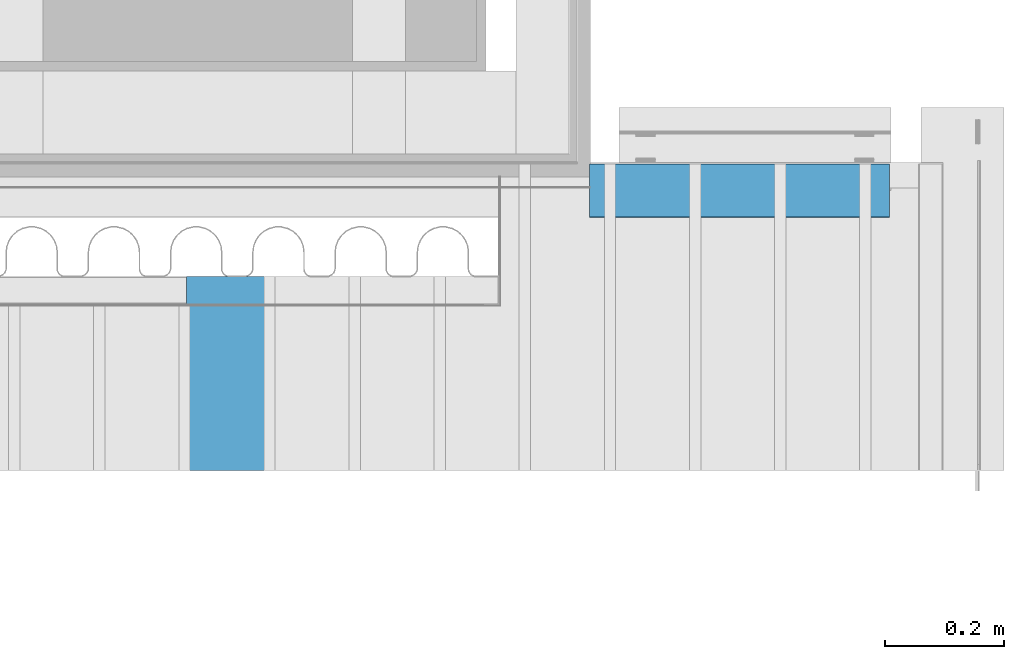
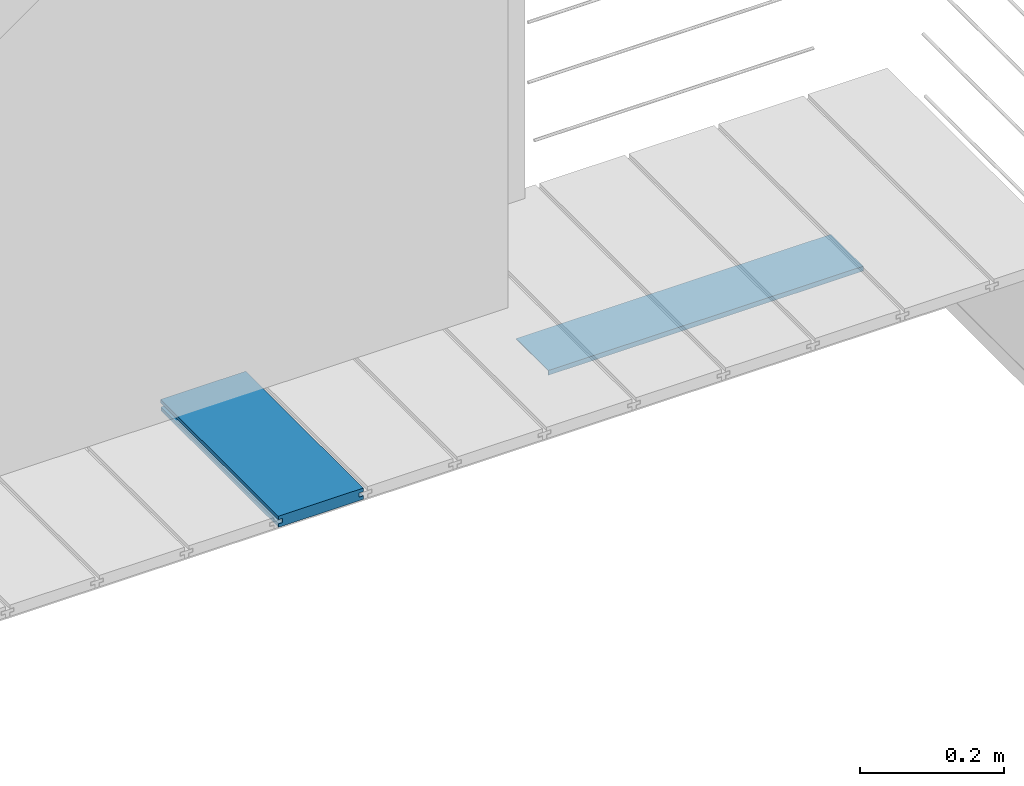
# One storey, part 23 of 33: 2 walls.
"""IFC4 building model written with IfcOpenShell, lengths in feet."""

from ifc_helpers import new_model, entity, si_unit, converted_unit, derived_unit, direction, frame, origin, place, context, subcontext, project, spatial, material, type_object, element, save


model = new_model("IFC4")

# Units and contexts
model_context = context("Model", 3, precision=0.0001, world=origin(), true_north=direction((6.12303176911189e-17, 1.0)))
body_context = subcontext(model_context, "Body", "Model", "MODEL_VIEW")
ifc_project = project(units=[converted_unit("LENGTHUNIT", "FOOT", entity("IfcRatioMeasure", 0.3048), si_unit("LENGTHUNIT", "METRE"), dimensions=[1, 0, 0, 0, 0, 0, 0]), converted_unit("AREAUNIT", "SQUARE FOOT", entity("IfcRatioMeasure", 0.09290304), si_unit("AREAUNIT", "SQUARE_METRE"), dimensions=[2, 0, 0, 0, 0, 0, 0]), converted_unit("VOLUMEUNIT", "CUBIC FOOT", entity("IfcRatioMeasure", 0.028316846592), si_unit("VOLUMEUNIT", "CUBIC_METRE"), dimensions=[3, 0, 0, 0, 0, 0, 0]), converted_unit("PLANEANGLEUNIT", "DEGREE", entity("IfcRatioMeasure", 0.0174532925199433), si_unit("PLANEANGLEUNIT", "RADIAN"), dimensions=[0, 0, 0, 0, 0, 0, 0]), si_unit("MASSUNIT", "GRAM", prefix="KILO"), derived_unit("MASSDENSITYUNIT", [(si_unit("MASSUNIT", "GRAM", prefix="KILO"), 1), (si_unit("LENGTHUNIT", "METRE"), -3)]), derived_unit("MOMENTOFINERTIAUNIT", [(si_unit("LENGTHUNIT", "METRE"), 4)]), si_unit("TIMEUNIT", "SECOND"), si_unit("FREQUENCYUNIT", "HERTZ"), si_unit("THERMODYNAMICTEMPERATUREUNIT", "DEGREE_CELSIUS"), derived_unit("THERMALTRANSMITTANCEUNIT", [(si_unit("MASSUNIT", "GRAM", prefix="KILO"), 1), (si_unit("THERMODYNAMICTEMPERATUREUNIT", "KELVIN"), -1), (si_unit("TIMEUNIT", "SECOND"), -3)]), derived_unit("VOLUMETRICFLOWRATEUNIT", [(si_unit("LENGTHUNIT", "METRE"), 3), (si_unit("TIMEUNIT", "SECOND"), -1)]), si_unit("ELECTRICCURRENTUNIT", "AMPERE"), si_unit("ELECTRICVOLTAGEUNIT", "VOLT"), si_unit("POWERUNIT", "WATT"), si_unit("FORCEUNIT", "NEWTON"), si_unit("ILLUMINANCEUNIT", "LUX"), si_unit("LUMINOUSFLUXUNIT", "LUMEN"), si_unit("LUMINOUSINTENSITYUNIT", "CANDELA"), derived_unit("USERDEFINED", [(si_unit("MASSUNIT", "GRAM", prefix="KILO"), -1), (si_unit("LENGTHUNIT", "METRE"), -2), (si_unit("TIMEUNIT", "SECOND"), 3), (si_unit("LUMINOUSFLUXUNIT", "LUMEN"), 1)]), derived_unit("LINEARVELOCITYUNIT", [(si_unit("LENGTHUNIT", "METRE"), 1), (si_unit("TIMEUNIT", "SECOND"), -1)]), si_unit("PRESSUREUNIT", "PASCAL"), derived_unit("USERDEFINED", [(si_unit("LENGTHUNIT", "METRE"), -2), (si_unit("MASSUNIT", "GRAM", prefix="KILO"), 1), (si_unit("TIMEUNIT", "SECOND"), -2)]), derived_unit("LINEARFORCEUNIT", [(si_unit("MASSUNIT", "GRAM", prefix="KILO"), 1), (si_unit("LENGTHUNIT", "METRE"), 1), (si_unit("TIMEUNIT", "SECOND"), -2), (si_unit("LENGTHUNIT", "METRE"), -1)]), derived_unit("PLANARFORCEUNIT", [(si_unit("MASSUNIT", "GRAM", prefix="KILO"), 1), (si_unit("LENGTHUNIT", "METRE"), 1), (si_unit("TIMEUNIT", "SECOND"), -2), (si_unit("LENGTHUNIT", "METRE"), -2)])], contexts=[model_context])

# Site, building, storey
site_placement = place(None, origin())
site = spatial("IfcSite", under=ifc_project, at=site_placement, CompositionType="ELEMENT")
building_placement = place(site_placement, origin())
building = spatial("IfcBuilding", under=site, at=building_placement, CompositionType="ELEMENT")
storey_placement = place(building_placement, frame((0.0, 0.0, 10.0)))
storey = spatial("IfcBuildingStorey", under=building, at=storey_placement, Name="2ND FLOOR", CompositionType="ELEMENT", Elevation=10.0000000000002)

# Walls
ifc_material_1 = material(Name="COMPOSITE DECKING W/ HIDDEN FASTENERS", Category="Materials")
wall_type_1 = type_object("IfcWallType", Name="Generic Models 716:Generic Models 1", PredefinedType="NOTDEFINED", material=ifc_material_1)
wall_1_placement = place(storey_placement, frame((1490.12212393819, 3.04611392999271, 0.68290215715014), z_axis=(0.0, 0.0, 1.0), x_axis=(0.0, 1.0, 0.0)))
cartesian_point_1 = entity("IfcCartesianPoint", [1.07004500651839, -0.446740923891412, 0.0])
vertex_point_1 = entity("IfcVertexPoint", cartesian_point_1)
cartesian_point_2 = entity("IfcCartesianPoint", [1.07004500651839, -0.00132475379450625, 0.0])
vertex_point_2 = entity("IfcVertexPoint", cartesian_point_2)
ifc_direction_1 = entity("IfcDirection", [0.0, 1.0, 0.0])
edge_curve_1 = entity("IfcEdgeCurve", vertex_point_1, vertex_point_2, entity("IfcTrimmedCurve", entity("IfcLine", cartesian_point_1, entity("IfcVector", ifc_direction_1, 1.0)), [cartesian_point_1], [cartesian_point_2], True, "CARTESIAN"), True)
cartesian_point_3 = entity("IfcCartesianPoint", [1.07004500651839, -0.00132475379450625, 0.0198779960861479])
vertex_point_3 = entity("IfcVertexPoint", cartesian_point_3)
ifc_direction_2 = entity("IfcDirection", [0.0, 0.0, 1.0])
edge_curve_2 = entity("IfcEdgeCurve", vertex_point_2, vertex_point_3, entity("IfcTrimmedCurve", entity("IfcLine", cartesian_point_2, entity("IfcVector", ifc_direction_2, 1.0)), [cartesian_point_2], [cartesian_point_3], True, "CARTESIAN"), True)
cartesian_point_4 = entity("IfcCartesianPoint", [1.07004500651839, -0.0228400010807945, 0.0198779960861479])
vertex_point_4 = entity("IfcVertexPoint", cartesian_point_4)
ifc_direction_3 = entity("IfcDirection", [0.0, -1.0, 0.0])
edge_curve_3 = entity("IfcEdgeCurve", vertex_point_3, vertex_point_4, entity("IfcTrimmedCurve", entity("IfcLine", cartesian_point_3, entity("IfcVector", ifc_direction_3, 1.0)), [cartesian_point_3], [cartesian_point_4], True, "CARTESIAN"), True)
cartesian_point_5 = entity("IfcCartesianPoint", [1.07004500651839, -0.0228400010807945, 0.0422987663426522])
vertex_point_5 = entity("IfcVertexPoint", cartesian_point_5)
edge_curve_4 = entity("IfcEdgeCurve", vertex_point_4, vertex_point_5, entity("IfcTrimmedCurve", entity("IfcLine", cartesian_point_4, entity("IfcVector", ifc_direction_2, 1.0)), [cartesian_point_4], [cartesian_point_5], True, "CARTESIAN"), True)
cartesian_point_6 = entity("IfcCartesianPoint", [1.07004500651839, 0.0, 0.0422987663426522])
vertex_point_6 = entity("IfcVertexPoint", cartesian_point_6)
edge_curve_5 = entity("IfcEdgeCurve", vertex_point_5, vertex_point_6, entity("IfcTrimmedCurve", entity("IfcLine", cartesian_point_5, entity("IfcVector", ifc_direction_1, 1.0)), [cartesian_point_5], [cartesian_point_6], True, "CARTESIAN"), True)
cartesian_point_7 = entity("IfcCartesianPoint", [1.07004500651839, 0.0, 0.0625000000000551])
vertex_point_7 = entity("IfcVertexPoint", cartesian_point_7)
edge_curve_6 = entity("IfcEdgeCurve", vertex_point_6, vertex_point_7, entity("IfcTrimmedCurve", entity("IfcLine", cartesian_point_6, entity("IfcVector", ifc_direction_2, 1.0)), [cartesian_point_6], [cartesian_point_7], True, "CARTESIAN"), True)
cartesian_point_8 = entity("IfcCartesianPoint", [1.07004500651839, -0.446740923891639, 0.0625])
vertex_point_8 = entity("IfcVertexPoint", cartesian_point_8)
edge_curve_7 = entity("IfcEdgeCurve", vertex_point_7, vertex_point_8, entity("IfcTrimmedCurve", entity("IfcLine", cartesian_point_7, entity("IfcVector", ifc_direction_3, 1.0)), [cartesian_point_7], [cartesian_point_8], True, "CARTESIAN"), True)
cartesian_point_9 = entity("IfcCartesianPoint", [1.07004500651839, -0.446740923891639, 0.0422987663426522])
vertex_point_9 = entity("IfcVertexPoint", cartesian_point_9)
ifc_direction_4 = entity("IfcDirection", [0.0, 0.0, -1.0])
edge_curve_8 = entity("IfcEdgeCurve", vertex_point_8, vertex_point_9, entity("IfcTrimmedCurve", entity("IfcLine", cartesian_point_8, entity("IfcVector", ifc_direction_4, 1.0)), [cartesian_point_8], [cartesian_point_9], True, "CARTESIAN"), True)
cartesian_point_10 = entity("IfcCartesianPoint", [1.07004500651839, -0.423900922810617, 0.0422987663426522])
vertex_point_10 = entity("IfcVertexPoint", cartesian_point_10)
edge_curve_9 = entity("IfcEdgeCurve", vertex_point_9, vertex_point_10, entity("IfcTrimmedCurve", entity("IfcLine", cartesian_point_9, entity("IfcVector", ifc_direction_1, 1.0)), [cartesian_point_9], [cartesian_point_10], True, "CARTESIAN"), True)
cartesian_point_11 = entity("IfcCartesianPoint", [1.07004500651839, -0.423900922810617, 0.0198779960861479])
vertex_point_11 = entity("IfcVertexPoint", cartesian_point_11)
edge_curve_10 = entity("IfcEdgeCurve", vertex_point_10, vertex_point_11, entity("IfcTrimmedCurve", entity("IfcLine", cartesian_point_10, entity("IfcVector", ifc_direction_4, 1.0)), [cartesian_point_10], [cartesian_point_11], True, "CARTESIAN"), True)
cartesian_point_12 = entity("IfcCartesianPoint", [1.07004500651839, -0.446740923891412, 0.0198779960861479])
vertex_point_12 = entity("IfcVertexPoint", cartesian_point_12)
edge_curve_11 = entity("IfcEdgeCurve", vertex_point_11, vertex_point_12, entity("IfcTrimmedCurve", entity("IfcLine", cartesian_point_11, entity("IfcVector", ifc_direction_3, 1.0)), [cartesian_point_11], [cartesian_point_12], True, "CARTESIAN"), True)
edge_curve_12 = entity("IfcEdgeCurve", vertex_point_12, vertex_point_1, entity("IfcTrimmedCurve", entity("IfcLine", cartesian_point_12, entity("IfcVector", ifc_direction_4, 1.0)), [cartesian_point_12], [cartesian_point_1], True, "CARTESIAN"), True)
ifc_direction_5 = entity("IfcDirection", [1.0, 0.0, 0.0])
cartesian_point_13 = entity("IfcCartesianPoint", [0.0, -0.446740923891412, 0.0])
vertex_point_13 = entity("IfcVertexPoint", cartesian_point_13)
cartesian_point_14 = entity("IfcCartesianPoint", [0.0, -0.446740923891412, 0.0198779960861479])
vertex_point_14 = entity("IfcVertexPoint", cartesian_point_14)
edge_curve_13 = entity("IfcEdgeCurve", vertex_point_13, vertex_point_14, entity("IfcTrimmedCurve", entity("IfcLine", cartesian_point_13, entity("IfcVector", ifc_direction_2, 1.0)), [cartesian_point_13], [cartesian_point_14], True, "CARTESIAN"), True)
cartesian_point_15 = entity("IfcCartesianPoint", [0.0, -0.423900922810617, 0.0198779960861479])
vertex_point_15 = entity("IfcVertexPoint", cartesian_point_15)
edge_curve_14 = entity("IfcEdgeCurve", vertex_point_14, vertex_point_15, entity("IfcTrimmedCurve", entity("IfcLine", cartesian_point_14, entity("IfcVector", ifc_direction_1, 1.0)), [cartesian_point_14], [cartesian_point_15], True, "CARTESIAN"), True)
cartesian_point_16 = entity("IfcCartesianPoint", [0.0, -0.423900922810617, 0.0422987663426522])
vertex_point_16 = entity("IfcVertexPoint", cartesian_point_16)
edge_curve_15 = entity("IfcEdgeCurve", vertex_point_15, vertex_point_16, entity("IfcTrimmedCurve", entity("IfcLine", cartesian_point_15, entity("IfcVector", ifc_direction_2, 1.0)), [cartesian_point_15], [cartesian_point_16], True, "CARTESIAN"), True)
cartesian_point_17 = entity("IfcCartesianPoint", [0.0, -0.446740923891639, 0.0422987663426522])
vertex_point_17 = entity("IfcVertexPoint", cartesian_point_17)
edge_curve_16 = entity("IfcEdgeCurve", vertex_point_16, vertex_point_17, entity("IfcTrimmedCurve", entity("IfcLine", cartesian_point_16, entity("IfcVector", ifc_direction_3, 1.0)), [cartesian_point_16], [cartesian_point_17], True, "CARTESIAN"), True)
cartesian_point_18 = entity("IfcCartesianPoint", [0.0, -0.446740923891639, 0.0625])
vertex_point_18 = entity("IfcVertexPoint", cartesian_point_18)
edge_curve_17 = entity("IfcEdgeCurve", vertex_point_17, vertex_point_18, entity("IfcTrimmedCurve", entity("IfcLine", cartesian_point_17, entity("IfcVector", ifc_direction_2, 1.0)), [cartesian_point_17], [cartesian_point_18], True, "CARTESIAN"), True)
cartesian_point_19 = entity("IfcCartesianPoint", [0.0, 0.0, 0.0625000000000551])
vertex_point_19 = entity("IfcVertexPoint", cartesian_point_19)
edge_curve_18 = entity("IfcEdgeCurve", vertex_point_18, vertex_point_19, entity("IfcTrimmedCurve", entity("IfcLine", cartesian_point_18, entity("IfcVector", ifc_direction_1, 1.0)), [cartesian_point_18], [cartesian_point_19], True, "CARTESIAN"), True)
cartesian_point_20 = entity("IfcCartesianPoint", [0.0, 0.0, 0.0422987663426522])
vertex_point_20 = entity("IfcVertexPoint", cartesian_point_20)
edge_curve_19 = entity("IfcEdgeCurve", vertex_point_19, vertex_point_20, entity("IfcTrimmedCurve", entity("IfcLine", cartesian_point_19, entity("IfcVector", ifc_direction_4, 1.0)), [cartesian_point_19], [cartesian_point_20], True, "CARTESIAN"), True)
cartesian_point_21 = entity("IfcCartesianPoint", [0.0, -0.0228400010807945, 0.0422987663426522])
vertex_point_21 = entity("IfcVertexPoint", cartesian_point_21)
edge_curve_20 = entity("IfcEdgeCurve", vertex_point_20, vertex_point_21, entity("IfcTrimmedCurve", entity("IfcLine", cartesian_point_20, entity("IfcVector", ifc_direction_3, 1.0)), [cartesian_point_20], [cartesian_point_21], True, "CARTESIAN"), True)
cartesian_point_22 = entity("IfcCartesianPoint", [0.0, -0.0228400010807945, 0.0198779960861479])
vertex_point_22 = entity("IfcVertexPoint", cartesian_point_22)
edge_curve_21 = entity("IfcEdgeCurve", vertex_point_21, vertex_point_22, entity("IfcTrimmedCurve", entity("IfcLine", cartesian_point_21, entity("IfcVector", ifc_direction_4, 1.0)), [cartesian_point_21], [cartesian_point_22], True, "CARTESIAN"), True)
cartesian_point_23 = entity("IfcCartesianPoint", [0.0, -0.00132475379450625, 0.0198779960861479])
vertex_point_23 = entity("IfcVertexPoint", cartesian_point_23)
edge_curve_22 = entity("IfcEdgeCurve", vertex_point_22, vertex_point_23, entity("IfcTrimmedCurve", entity("IfcLine", cartesian_point_22, entity("IfcVector", ifc_direction_1, 1.0)), [cartesian_point_22], [cartesian_point_23], True, "CARTESIAN"), True)
cartesian_point_24 = entity("IfcCartesianPoint", [0.0, -0.00132475379450625, 0.0])
vertex_point_24 = entity("IfcVertexPoint", cartesian_point_24)
edge_curve_23 = entity("IfcEdgeCurve", vertex_point_23, vertex_point_24, entity("IfcTrimmedCurve", entity("IfcLine", cartesian_point_23, entity("IfcVector", ifc_direction_4, 1.0)), [cartesian_point_23], [cartesian_point_24], True, "CARTESIAN"), True)
edge_curve_24 = entity("IfcEdgeCurve", vertex_point_24, vertex_point_13, entity("IfcTrimmedCurve", entity("IfcLine", cartesian_point_24, entity("IfcVector", ifc_direction_3, 1.0)), [cartesian_point_24], [cartesian_point_13], True, "CARTESIAN"), True)
ifc_direction_6 = entity("IfcDirection", [-1.0, 0.0, 0.0])
edge_curve_25 = entity("IfcEdgeCurve", vertex_point_13, vertex_point_1, entity("IfcTrimmedCurve", entity("IfcLine", cartesian_point_13, entity("IfcVector", ifc_direction_5, 1.0)), [cartesian_point_13], [cartesian_point_1], True, "CARTESIAN"), True)
edge_curve_26 = entity("IfcEdgeCurve", vertex_point_12, vertex_point_14, entity("IfcTrimmedCurve", entity("IfcLine", cartesian_point_14, entity("IfcVector", ifc_direction_6, 1.0)), [cartesian_point_12], [cartesian_point_14], True, "CARTESIAN"), True)
edge_curve_27 = entity("IfcEdgeCurve", vertex_point_18, vertex_point_8, entity("IfcTrimmedCurve", entity("IfcLine", cartesian_point_18, entity("IfcVector", ifc_direction_5, 1.0)), [cartesian_point_18], [cartesian_point_8], True, "CARTESIAN"), True)
edge_curve_28 = entity("IfcEdgeCurve", vertex_point_7, vertex_point_19, entity("IfcTrimmedCurve", entity("IfcLine", cartesian_point_19, entity("IfcVector", ifc_direction_6, 1.0)), [cartesian_point_7], [cartesian_point_19], True, "CARTESIAN"), True)
edge_curve_29 = entity("IfcEdgeCurve", vertex_point_6, vertex_point_20, entity("IfcTrimmedCurve", entity("IfcLine", cartesian_point_20, entity("IfcVector", ifc_direction_6, 1.0)), [cartesian_point_6], [cartesian_point_20], True, "CARTESIAN"), True)
edge_curve_30 = entity("IfcEdgeCurve", vertex_point_24, vertex_point_2, entity("IfcTrimmedCurve", entity("IfcLine", cartesian_point_24, entity("IfcVector", ifc_direction_5, 1.0)), [cartesian_point_24], [cartesian_point_2], True, "CARTESIAN"), True)
edge_curve_31 = entity("IfcEdgeCurve", vertex_point_17, vertex_point_9, entity("IfcTrimmedCurve", entity("IfcLine", cartesian_point_17, entity("IfcVector", ifc_direction_5, 1.0)), [cartesian_point_17], [cartesian_point_9], True, "CARTESIAN"), True)
edge_curve_32 = entity("IfcEdgeCurve", vertex_point_5, vertex_point_21, entity("IfcTrimmedCurve", entity("IfcLine", cartesian_point_21, entity("IfcVector", ifc_direction_6, 1.0)), [cartesian_point_5], [cartesian_point_21], True, "CARTESIAN"), True)
edge_curve_33 = entity("IfcEdgeCurve", vertex_point_4, vertex_point_22, entity("IfcTrimmedCurve", entity("IfcLine", cartesian_point_22, entity("IfcVector", ifc_direction_6, 1.0)), [cartesian_point_4], [cartesian_point_22], True, "CARTESIAN"), True)
edge_curve_34 = entity("IfcEdgeCurve", vertex_point_3, vertex_point_23, entity("IfcTrimmedCurve", entity("IfcLine", cartesian_point_23, entity("IfcVector", ifc_direction_6, 1.0)), [cartesian_point_3], [cartesian_point_23], True, "CARTESIAN"), True)
edge_curve_35 = entity("IfcEdgeCurve", vertex_point_11, vertex_point_15, entity("IfcTrimmedCurve", entity("IfcLine", cartesian_point_15, entity("IfcVector", ifc_direction_6, 1.0)), [cartesian_point_11], [cartesian_point_15], True, "CARTESIAN"), True)
edge_curve_36 = entity("IfcEdgeCurve", vertex_point_10, vertex_point_16, entity("IfcTrimmedCurve", entity("IfcLine", cartesian_point_16, entity("IfcVector", ifc_direction_6, 1.0)), [cartesian_point_10], [cartesian_point_16], True, "CARTESIAN"), True)
element("IfcWall", 1, at=wall_1_placement, inside=storey, type_object=wall_type_1, material=ifc_material_1, Name="Generic Models 716:Generic Models 1", ObjectType="Generic Models 716:Generic Models 1", PredefinedType="NOTDEFINED", context=body_context, shape_type="AdvancedBrep", body=[
    entity("IfcAdvancedBrep", entity("IfcClosedShell", [entity("IfcAdvancedFace", [entity("IfcFaceOuterBound", entity("IfcEdgeLoop", [entity("IfcOrientedEdge", None, None, edge_curve_1, True), entity("IfcOrientedEdge", None, None, edge_curve_2, True), entity("IfcOrientedEdge", None, None, edge_curve_3, True), entity("IfcOrientedEdge", None, None, edge_curve_4, True), entity("IfcOrientedEdge", None, None, edge_curve_5, True), entity("IfcOrientedEdge", None, None, edge_curve_6, True), entity("IfcOrientedEdge", None, None, edge_curve_7, True), entity("IfcOrientedEdge", None, None, edge_curve_8, True), entity("IfcOrientedEdge", None, None, edge_curve_9, True), entity("IfcOrientedEdge", None, None, edge_curve_10, True), entity("IfcOrientedEdge", None, None, edge_curve_11, True), entity("IfcOrientedEdge", None, None, edge_curve_12, True)]), True)], entity("IfcPlane", entity("IfcAxis2Placement3D", entity("IfcCartesianPoint", [1.07004500651839, -0.446740923891412, -0.0208333333328241]), ifc_direction_5, ifc_direction_4)), True), entity("IfcAdvancedFace", [entity("IfcFaceOuterBound", entity("IfcEdgeLoop", [entity("IfcOrientedEdge", None, None, edge_curve_13, True), entity("IfcOrientedEdge", None, None, edge_curve_14, True), entity("IfcOrientedEdge", None, None, edge_curve_15, True), entity("IfcOrientedEdge", None, None, edge_curve_16, True), entity("IfcOrientedEdge", None, None, edge_curve_17, True), entity("IfcOrientedEdge", None, None, edge_curve_18, True), entity("IfcOrientedEdge", None, None, edge_curve_19, True), entity("IfcOrientedEdge", None, None, edge_curve_20, True), entity("IfcOrientedEdge", None, None, edge_curve_21, True), entity("IfcOrientedEdge", None, None, edge_curve_22, True), entity("IfcOrientedEdge", None, None, edge_curve_23, True), entity("IfcOrientedEdge", None, None, edge_curve_24, True)]), True)], entity("IfcPlane", entity("IfcAxis2Placement3D", entity("IfcCartesianPoint", [0.0, -0.446740923891412, -0.0208333333328241]), ifc_direction_6, ifc_direction_2)), True), entity("IfcAdvancedFace", [entity("IfcFaceOuterBound", entity("IfcEdgeLoop", [entity("IfcOrientedEdge", None, None, edge_curve_13, False), entity("IfcOrientedEdge", None, None, edge_curve_25, True), entity("IfcOrientedEdge", None, None, edge_curve_12, False), entity("IfcOrientedEdge", None, None, edge_curve_26, True)]), True)], entity("IfcPlane", entity("IfcAxis2Placement3D", cartesian_point_13, ifc_direction_3, ifc_direction_5)), True), entity("IfcAdvancedFace", [entity("IfcFaceOuterBound", entity("IfcEdgeLoop", [entity("IfcOrientedEdge", None, None, edge_curve_18, False), entity("IfcOrientedEdge", None, None, edge_curve_27, True), entity("IfcOrientedEdge", None, None, edge_curve_7, False), entity("IfcOrientedEdge", None, None, edge_curve_28, True)]), True)], entity("IfcPlane", entity("IfcAxis2Placement3D", cartesian_point_18, ifc_direction_2, ifc_direction_5)), True), entity("IfcAdvancedFace", [entity("IfcFaceOuterBound", entity("IfcEdgeLoop", [entity("IfcOrientedEdge", None, None, edge_curve_19, False), entity("IfcOrientedEdge", None, None, edge_curve_28, False), entity("IfcOrientedEdge", None, None, edge_curve_6, False), entity("IfcOrientedEdge", None, None, edge_curve_29, True)]), True)], entity("IfcPlane", entity("IfcAxis2Placement3D", cartesian_point_19, ifc_direction_1, ifc_direction_5)), True), entity("IfcAdvancedFace", [entity("IfcFaceOuterBound", entity("IfcEdgeLoop", [entity("IfcOrientedEdge", None, None, edge_curve_24, False), entity("IfcOrientedEdge", None, None, edge_curve_30, True), entity("IfcOrientedEdge", None, None, edge_curve_1, False), entity("IfcOrientedEdge", None, None, edge_curve_25, False)]), True)], entity("IfcPlane", entity("IfcAxis2Placement3D", cartesian_point_24, ifc_direction_4, ifc_direction_5)), True), entity("IfcAdvancedFace", [entity("IfcFaceOuterBound", entity("IfcEdgeLoop", [entity("IfcOrientedEdge", None, None, edge_curve_17, False), entity("IfcOrientedEdge", None, None, edge_curve_31, True), entity("IfcOrientedEdge", None, None, edge_curve_8, False), entity("IfcOrientedEdge", None, None, edge_curve_27, False)]), True)], entity("IfcPlane", entity("IfcAxis2Placement3D", cartesian_point_17, ifc_direction_3, ifc_direction_5)), True), entity("IfcAdvancedFace", [entity("IfcFaceOuterBound", entity("IfcEdgeLoop", [entity("IfcOrientedEdge", None, None, edge_curve_20, False), entity("IfcOrientedEdge", None, None, edge_curve_29, False), entity("IfcOrientedEdge", None, None, edge_curve_5, False), entity("IfcOrientedEdge", None, None, edge_curve_32, True)]), True)], entity("IfcPlane", entity("IfcAxis2Placement3D", cartesian_point_20, ifc_direction_4, ifc_direction_5)), True), entity("IfcAdvancedFace", [entity("IfcFaceOuterBound", entity("IfcEdgeLoop", [entity("IfcOrientedEdge", None, None, edge_curve_21, False), entity("IfcOrientedEdge", None, None, edge_curve_32, False), entity("IfcOrientedEdge", None, None, edge_curve_4, False), entity("IfcOrientedEdge", None, None, edge_curve_33, True)]), True)], entity("IfcPlane", entity("IfcAxis2Placement3D", cartesian_point_21, ifc_direction_1, ifc_direction_5)), True), entity("IfcAdvancedFace", [entity("IfcFaceOuterBound", entity("IfcEdgeLoop", [entity("IfcOrientedEdge", None, None, edge_curve_22, False), entity("IfcOrientedEdge", None, None, edge_curve_33, False), entity("IfcOrientedEdge", None, None, edge_curve_3, False), entity("IfcOrientedEdge", None, None, edge_curve_34, True)]), True)], entity("IfcPlane", entity("IfcAxis2Placement3D", cartesian_point_22, ifc_direction_2, ifc_direction_5)), True), entity("IfcAdvancedFace", [entity("IfcFaceOuterBound", entity("IfcEdgeLoop", [entity("IfcOrientedEdge", None, None, edge_curve_23, False), entity("IfcOrientedEdge", None, None, edge_curve_34, False), entity("IfcOrientedEdge", None, None, edge_curve_2, False), entity("IfcOrientedEdge", None, None, edge_curve_30, False)]), True)], entity("IfcPlane", entity("IfcAxis2Placement3D", cartesian_point_23, ifc_direction_1, ifc_direction_5)), True), entity("IfcAdvancedFace", [entity("IfcFaceOuterBound", entity("IfcEdgeLoop", [entity("IfcOrientedEdge", None, None, edge_curve_14, False), entity("IfcOrientedEdge", None, None, edge_curve_26, False), entity("IfcOrientedEdge", None, None, edge_curve_11, False), entity("IfcOrientedEdge", None, None, edge_curve_35, True)]), True)], entity("IfcPlane", entity("IfcAxis2Placement3D", cartesian_point_14, ifc_direction_2, ifc_direction_5)), True), entity("IfcAdvancedFace", [entity("IfcFaceOuterBound", entity("IfcEdgeLoop", [entity("IfcOrientedEdge", None, None, edge_curve_15, False), entity("IfcOrientedEdge", None, None, edge_curve_35, False), entity("IfcOrientedEdge", None, None, edge_curve_10, False), entity("IfcOrientedEdge", None, None, edge_curve_36, True)]), True)], entity("IfcPlane", entity("IfcAxis2Placement3D", cartesian_point_15, ifc_direction_3, ifc_direction_5)), True), entity("IfcAdvancedFace", [entity("IfcFaceOuterBound", entity("IfcEdgeLoop", [entity("IfcOrientedEdge", None, None, edge_curve_16, False), entity("IfcOrientedEdge", None, None, edge_curve_36, False), entity("IfcOrientedEdge", None, None, edge_curve_9, False), entity("IfcOrientedEdge", None, None, edge_curve_31, False)]), True)], entity("IfcPlane", entity("IfcAxis2Placement3D", cartesian_point_16, ifc_direction_4, ifc_direction_5)), True)])),
])
ifc_material_2 = material(Name="METAL FLASHING - BLACK", Category="Materials")
wall_type_2 = type_object("IfcWallType", Name="Generic Models 726:Generic Models 1", PredefinedType="NOTDEFINED", material=ifc_material_2)
wall_2_placement = place(storey_placement, frame((1492.34742463162, 4.44388521335058, -0.100163566569503)))
cartesian_point_25 = entity("IfcCartesianPoint", [0.0, 0.294688157749044, 0.0233852536726094])
vertex_point_25 = entity("IfcVertexPoint", cartesian_point_25)
cartesian_point_26 = entity("IfcCartesianPoint", [0.0, 0.00402935756425826, 0.0233852536726094])
vertex_point_26 = entity("IfcVertexPoint", cartesian_point_26)
ifc_direction_7 = entity("IfcDirection", [0.0, -1.0, 0.0])
edge_curve_37 = entity("IfcEdgeCurve", vertex_point_25, vertex_point_26, entity("IfcTrimmedCurve", entity("IfcLine", cartesian_point_25, entity("IfcVector", ifc_direction_7, 1.0)), [cartesian_point_25], [cartesian_point_26], True, "CARTESIAN"), True)
cartesian_point_27 = entity("IfcCartesianPoint", [0.0, 0.00450293920002309, 0.000565374130363949])
vertex_point_27 = entity("IfcVertexPoint", cartesian_point_27)
cartesian_point_28 = entity("IfcCartesianPoint", [0.0, 0.0690719683980001, 0.0133202310029716])
ifc_direction_8 = entity("IfcDirection", [1.0, 0.0, 0.0])
edge_curve_38 = entity("IfcEdgeCurve", vertex_point_26, vertex_point_27, entity("IfcTrimmedCurve", entity("IfcCircle", entity("IfcAxis2Placement3D", cartesian_point_28, ifc_direction_8, ifc_direction_7), 0.0658167600646667), [cartesian_point_26], [cartesian_point_27], True, "CARTESIAN"), True)
cartesian_point_29 = entity("IfcCartesianPoint", [0.0, 0.00129654317320504, 0.0])
vertex_point_28 = entity("IfcVertexPoint", cartesian_point_29)
edge_curve_39 = entity("IfcEdgeCurve", vertex_point_27, vertex_point_28, entity("IfcTrimmedCurve", entity("IfcLine", cartesian_point_27, entity("IfcVector", entity("IfcDirection", [0.0, -0.984807753012234, -0.173648177666783]), 1.0)), [cartesian_point_27], [cartesian_point_29], True, "CARTESIAN"), True)
cartesian_point_30 = entity("IfcCartesianPoint", [0.0, 0.00129654317320504, 0.0266404620059433])
vertex_point_29 = entity("IfcVertexPoint", cartesian_point_30)
ifc_direction_9 = entity("IfcDirection", [-1.0, 0.0, 0.0])
edge_curve_40 = entity("IfcEdgeCurve", vertex_point_28, vertex_point_29, entity("IfcTrimmedCurve", entity("IfcCircle", entity("IfcAxis2Placement3D", cartesian_point_28, ifc_direction_9, ifc_direction_7), 0.069071968398), [cartesian_point_29], [cartesian_point_30], True, "CARTESIAN"), True)
cartesian_point_31 = entity("IfcCartesianPoint", [0.0, 0.294688157749044, 0.0266404620059433])
vertex_point_30 = entity("IfcVertexPoint", cartesian_point_31)
ifc_direction_10 = entity("IfcDirection", [0.0, 1.0, 0.0])
edge_curve_41 = entity("IfcEdgeCurve", vertex_point_29, vertex_point_30, entity("IfcTrimmedCurve", entity("IfcLine", cartesian_point_30, entity("IfcVector", ifc_direction_10, 1.0)), [cartesian_point_30], [cartesian_point_31], True, "CARTESIAN"), True)
ifc_direction_11 = entity("IfcDirection", [0.0, 0.0, -1.0])
edge_curve_42 = entity("IfcEdgeCurve", vertex_point_30, vertex_point_25, entity("IfcTrimmedCurve", entity("IfcLine", cartesian_point_31, entity("IfcVector", ifc_direction_11, 1.0)), [cartesian_point_31], [cartesian_point_25], True, "CARTESIAN"), True)
cartesian_point_32 = entity("IfcCartesianPoint", [1.65386330547403, 0.294688157749071, 0.0233852536726147])
vertex_point_31 = entity("IfcVertexPoint", cartesian_point_32)
cartesian_point_33 = entity("IfcCartesianPoint", [1.65386330547403, 0.294688157749071, 0.0266404620059486])
vertex_point_32 = entity("IfcVertexPoint", cartesian_point_33)
ifc_direction_12 = entity("IfcDirection", [0.0, 0.0, 1.0])
edge_curve_43 = entity("IfcEdgeCurve", vertex_point_31, vertex_point_32, entity("IfcTrimmedCurve", entity("IfcLine", cartesian_point_32, entity("IfcVector", ifc_direction_12, 1.0)), [cartesian_point_32], [cartesian_point_33], True, "CARTESIAN"), True)
cartesian_point_34 = entity("IfcCartesianPoint", [1.65386330547403, 0.00129654317323258, 0.0266404620059468])
vertex_point_33 = entity("IfcVertexPoint", cartesian_point_34)
edge_curve_44 = entity("IfcEdgeCurve", vertex_point_32, vertex_point_33, entity("IfcTrimmedCurve", entity("IfcLine", cartesian_point_33, entity("IfcVector", ifc_direction_7, 1.0)), [cartesian_point_33], [cartesian_point_34], True, "CARTESIAN"), True)
cartesian_point_35 = entity("IfcCartesianPoint", [1.65386330547403, 0.00129654317323258, 0.0])
vertex_point_34 = entity("IfcVertexPoint", cartesian_point_35)
cartesian_point_36 = entity("IfcCartesianPoint", [1.65386330547403, 0.0690719683980277, 0.0133202310029752])
edge_curve_45 = entity("IfcEdgeCurve", vertex_point_33, vertex_point_34, entity("IfcTrimmedCurve", entity("IfcCircle", entity("IfcAxis2Placement3D", cartesian_point_36, ifc_direction_8, ifc_direction_7), 0.069071968398), [cartesian_point_34], [cartesian_point_35], True, "CARTESIAN"), True)
cartesian_point_37 = entity("IfcCartesianPoint", [1.65386330547403, 0.00450293920005063, 0.000565374130367502])
vertex_point_35 = entity("IfcVertexPoint", cartesian_point_37)
edge_curve_46 = entity("IfcEdgeCurve", vertex_point_34, vertex_point_35, entity("IfcTrimmedCurve", entity("IfcLine", cartesian_point_35, entity("IfcVector", entity("IfcDirection", [0.0, 0.984807753012234, 0.173648177666783]), 1.0)), [cartesian_point_35], [cartesian_point_37], True, "CARTESIAN"), True)
cartesian_point_38 = entity("IfcCartesianPoint", [1.65386330547403, 0.0040293575642858, 0.0233852536726129])
vertex_point_36 = entity("IfcVertexPoint", cartesian_point_38)
edge_curve_47 = entity("IfcEdgeCurve", vertex_point_35, vertex_point_36, entity("IfcTrimmedCurve", entity("IfcCircle", entity("IfcAxis2Placement3D", cartesian_point_36, ifc_direction_9, ifc_direction_7), 0.0658167600646667), [cartesian_point_37], [cartesian_point_38], True, "CARTESIAN"), True)
edge_curve_48 = entity("IfcEdgeCurve", vertex_point_36, vertex_point_31, entity("IfcTrimmedCurve", entity("IfcLine", cartesian_point_38, entity("IfcVector", ifc_direction_10, 1.0)), [cartesian_point_38], [cartesian_point_32], True, "CARTESIAN"), True)
edge_curve_49 = entity("IfcEdgeCurve", vertex_point_36, vertex_point_26, entity("IfcTrimmedCurve", entity("IfcLine", cartesian_point_38, entity("IfcVector", ifc_direction_9, 1.0)), [cartesian_point_38], [cartesian_point_26], True, "CARTESIAN"), True)
edge_curve_50 = entity("IfcEdgeCurve", vertex_point_25, vertex_point_31, entity("IfcTrimmedCurve", entity("IfcLine", cartesian_point_32, entity("IfcVector", ifc_direction_8, 1.0)), [cartesian_point_25], [cartesian_point_32], True, "CARTESIAN"), True)
edge_curve_51 = entity("IfcEdgeCurve", vertex_point_32, vertex_point_30, entity("IfcTrimmedCurve", entity("IfcLine", cartesian_point_33, entity("IfcVector", ifc_direction_9, 1.0)), [cartesian_point_33], [cartesian_point_31], True, "CARTESIAN"), True)
edge_curve_52 = entity("IfcEdgeCurve", vertex_point_29, vertex_point_33, entity("IfcTrimmedCurve", entity("IfcLine", cartesian_point_34, entity("IfcVector", ifc_direction_8, 1.0)), [cartesian_point_30], [cartesian_point_34], True, "CARTESIAN"), True)
edge_curve_53 = entity("IfcEdgeCurve", vertex_point_34, vertex_point_28, entity("IfcTrimmedCurve", entity("IfcLine", cartesian_point_35, entity("IfcVector", ifc_direction_9, 1.0)), [cartesian_point_35], [cartesian_point_29], True, "CARTESIAN"), True)
edge_curve_54 = entity("IfcEdgeCurve", vertex_point_27, vertex_point_35, entity("IfcTrimmedCurve", entity("IfcLine", cartesian_point_37, entity("IfcVector", ifc_direction_8, 1.0)), [cartesian_point_27], [cartesian_point_37], True, "CARTESIAN"), True)
element("IfcWall", 2, at=wall_2_placement, inside=storey, type_object=wall_type_2, material=ifc_material_2, Name="Generic Models 726:Generic Models 1", ObjectType="Generic Models 726:Generic Models 1", PredefinedType="NOTDEFINED", context=body_context, shape_type="AdvancedBrep", body=[
    entity("IfcAdvancedBrep", entity("IfcClosedShell", [entity("IfcAdvancedFace", [entity("IfcFaceOuterBound", entity("IfcEdgeLoop", [entity("IfcOrientedEdge", None, None, edge_curve_37, True), entity("IfcOrientedEdge", None, None, edge_curve_38, True), entity("IfcOrientedEdge", None, None, edge_curve_39, True), entity("IfcOrientedEdge", None, None, edge_curve_40, True), entity("IfcOrientedEdge", None, None, edge_curve_41, True), entity("IfcOrientedEdge", None, None, edge_curve_42, True)]), True)], entity("IfcPlane", entity("IfcAxis2Placement3D", entity("IfcCartesianPoint", [0.0, 0.294688157749044, -2.47781055031747]), ifc_direction_9, ifc_direction_11)), True), entity("IfcAdvancedFace", [entity("IfcFaceOuterBound", entity("IfcEdgeLoop", [entity("IfcOrientedEdge", None, None, edge_curve_43, True), entity("IfcOrientedEdge", None, None, edge_curve_44, True), entity("IfcOrientedEdge", None, None, edge_curve_45, True), entity("IfcOrientedEdge", None, None, edge_curve_46, True), entity("IfcOrientedEdge", None, None, edge_curve_47, True), entity("IfcOrientedEdge", None, None, edge_curve_48, True)]), True)], entity("IfcPlane", entity("IfcAxis2Placement3D", entity("IfcCartesianPoint", [1.65386330547403, 0.294688157749071, -2.47781055031747]), ifc_direction_8, ifc_direction_12)), True), entity("IfcAdvancedFace", [entity("IfcFaceOuterBound", entity("IfcEdgeLoop", [entity("IfcOrientedEdge", None, None, edge_curve_48, False), entity("IfcOrientedEdge", None, None, edge_curve_49, True), entity("IfcOrientedEdge", None, None, edge_curve_37, False), entity("IfcOrientedEdge", None, None, edge_curve_50, True)]), True)], entity("IfcPlane", entity("IfcAxis2Placement3D", cartesian_point_38, ifc_direction_11, ifc_direction_9)), True), entity("IfcAdvancedFace", [entity("IfcFaceOuterBound", entity("IfcEdgeLoop", [entity("IfcOrientedEdge", None, None, edge_curve_44, False), entity("IfcOrientedEdge", None, None, edge_curve_51, True), entity("IfcOrientedEdge", None, None, edge_curve_41, False), entity("IfcOrientedEdge", None, None, edge_curve_52, True)]), True)], entity("IfcPlane", entity("IfcAxis2Placement3D", cartesian_point_33, ifc_direction_12, ifc_direction_9)), True), entity("IfcAdvancedFace", [entity("IfcFaceOuterBound", entity("IfcEdgeLoop", [entity("IfcOrientedEdge", None, None, edge_curve_43, False), entity("IfcOrientedEdge", None, None, edge_curve_50, False), entity("IfcOrientedEdge", None, None, edge_curve_42, False), entity("IfcOrientedEdge", None, None, edge_curve_51, False)]), True)], entity("IfcPlane", entity("IfcAxis2Placement3D", cartesian_point_32, ifc_direction_10, ifc_direction_9)), True), entity("IfcAdvancedFace", [entity("IfcFaceOuterBound", entity("IfcEdgeLoop", [entity("IfcOrientedEdge", None, None, edge_curve_46, False), entity("IfcOrientedEdge", None, None, edge_curve_53, True), entity("IfcOrientedEdge", None, None, edge_curve_39, False), entity("IfcOrientedEdge", None, None, edge_curve_54, True)]), True)], entity("IfcPlane", entity("IfcAxis2Placement3D", cartesian_point_35, entity("IfcDirection", [0.0, 0.173648177666783, -0.984807753012234]), ifc_direction_9)), True), entity("IfcAdvancedFace", [entity("IfcFaceOuterBound", entity("IfcEdgeLoop", [entity("IfcOrientedEdge", None, None, edge_curve_47, False), entity("IfcOrientedEdge", None, None, edge_curve_54, False), entity("IfcOrientedEdge", None, None, edge_curve_38, False), entity("IfcOrientedEdge", None, None, edge_curve_49, False)]), True)], entity("IfcCylindricalSurface", entity("IfcAxis2Placement3D", cartesian_point_28, ifc_direction_9, ifc_direction_7), 0.0658167600646667), False), entity("IfcAdvancedFace", [entity("IfcFaceOuterBound", entity("IfcEdgeLoop", [entity("IfcOrientedEdge", None, None, edge_curve_45, False), entity("IfcOrientedEdge", None, None, edge_curve_52, False), entity("IfcOrientedEdge", None, None, edge_curve_40, False), entity("IfcOrientedEdge", None, None, edge_curve_53, False)]), True)], entity("IfcCylindricalSurface", entity("IfcAxis2Placement3D", cartesian_point_28, ifc_direction_8, ifc_direction_7), 0.069071968398), True)])),
])

save(model, "model.ifc")
